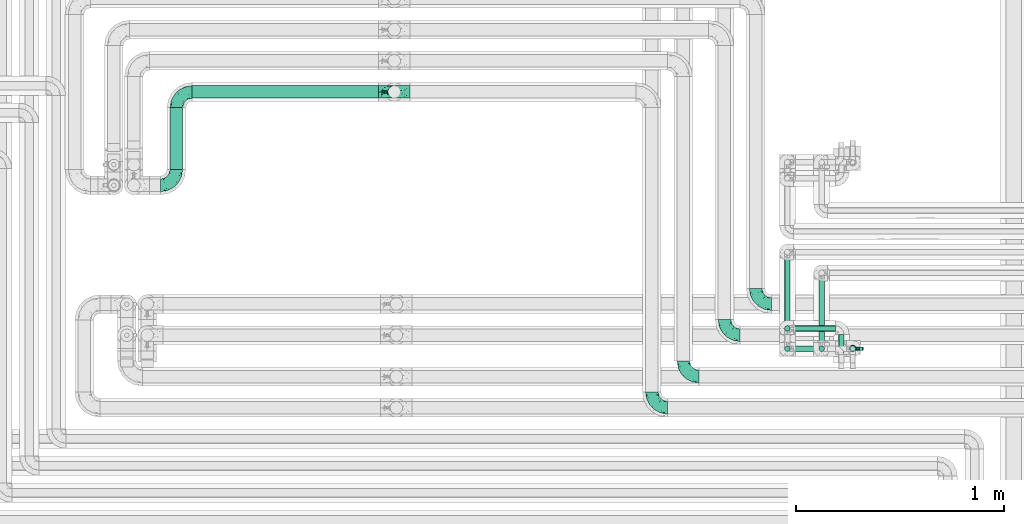
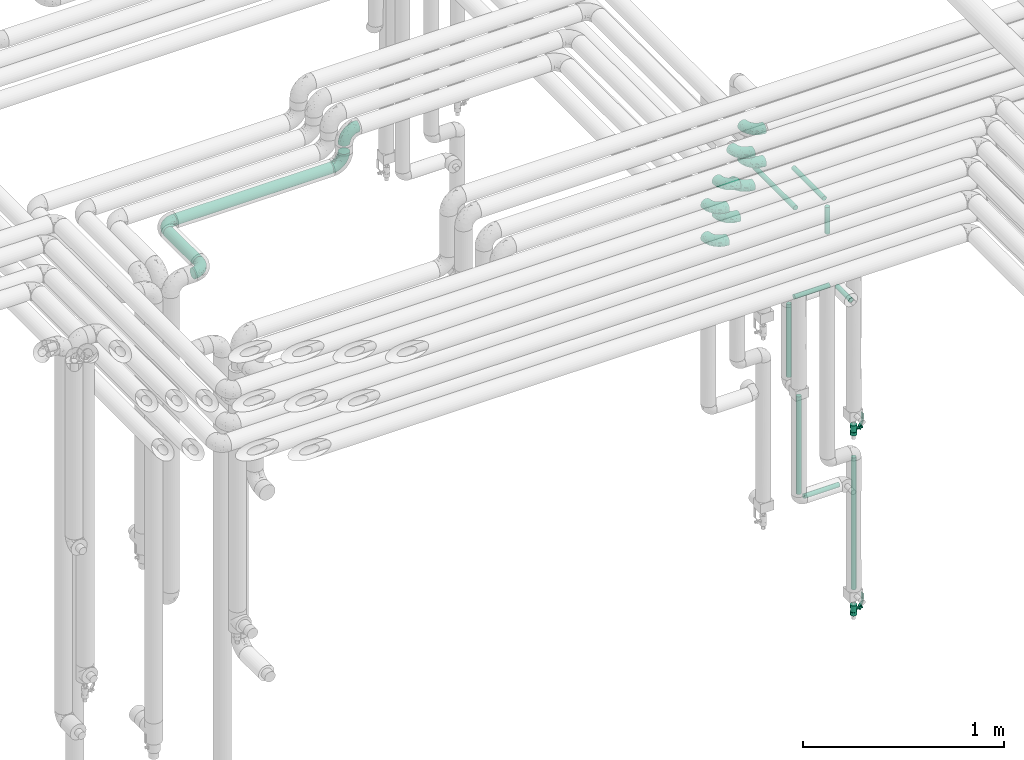
# One storey, part 635 of 827: 12 flow fittings, 11 flow segments, 2 flow controllers.
"""IFC2X3 building model written with IfcOpenShell, lengths in millimetres."""

from ifc_helpers import new_model, entity, si_unit, converted_unit, derived_unit, direction, frame, origin, origin_2d_with_axis, place, context, subcontext, project, spatial, polyline, circle, outline, extrude, faceted_brep, source, transform, mapped, material, material_list, type_object, type_shapes, element, save


model = new_model("IFC2X3")

# Units and contexts
model_context = context("Model", 3, precision=0.01, world=origin(), true_north=direction((6.12303176911189e-17, 1.0)))
body_context = subcontext(model_context, "Body", "Model", "MODEL_VIEW")
ifc_project = project(units=[si_unit("LENGTHUNIT", "METRE", prefix="MILLI"), si_unit("AREAUNIT", "SQUARE_METRE"), si_unit("VOLUMEUNIT", "CUBIC_METRE"), converted_unit("PLANEANGLEUNIT", "DEGREE", entity("IfcRatioMeasure", 0.0174532925199433), si_unit("PLANEANGLEUNIT", "RADIAN"), dimensions=[0, 0, 0, 0, 0, 0, 0]), si_unit("MASSUNIT", "GRAM", prefix="KILO"), derived_unit("MASSDENSITYUNIT", [(si_unit("MASSUNIT", "GRAM", prefix="KILO"), 1), (si_unit("LENGTHUNIT", "METRE"), -3)]), derived_unit("MOMENTOFINERTIAUNIT", [(si_unit("LENGTHUNIT", "METRE"), 4)]), si_unit("TIMEUNIT", "SECOND"), si_unit("FREQUENCYUNIT", "HERTZ"), si_unit("THERMODYNAMICTEMPERATUREUNIT", "DEGREE_CELSIUS"), derived_unit("THERMALTRANSMITTANCEUNIT", [(si_unit("MASSUNIT", "GRAM", prefix="KILO"), 1), (si_unit("THERMODYNAMICTEMPERATUREUNIT", "KELVIN"), -1), (si_unit("TIMEUNIT", "SECOND"), -3)]), derived_unit("VOLUMETRICFLOWRATEUNIT", [(si_unit("LENGTHUNIT", "METRE"), 3), (si_unit("TIMEUNIT", "SECOND"), -1)]), derived_unit("MASSFLOWRATEUNIT", [(si_unit("MASSUNIT", "GRAM", prefix="KILO"), 1), (si_unit("TIMEUNIT", "SECOND"), -1)]), derived_unit("ROTATIONALFREQUENCYUNIT", [(si_unit("TIMEUNIT", "SECOND"), -1)]), si_unit("ELECTRICCURRENTUNIT", "AMPERE"), si_unit("ELECTRICVOLTAGEUNIT", "VOLT"), si_unit("POWERUNIT", "WATT"), si_unit("FORCEUNIT", "NEWTON", prefix="KILO"), si_unit("ILLUMINANCEUNIT", "LUX"), si_unit("LUMINOUSFLUXUNIT", "LUMEN"), si_unit("LUMINOUSINTENSITYUNIT", "CANDELA"), derived_unit("USERDEFINED", [(si_unit("MASSUNIT", "GRAM", prefix="KILO"), -1), (si_unit("LENGTHUNIT", "METRE"), -2), (si_unit("TIMEUNIT", "SECOND"), 3), (si_unit("LUMINOUSFLUXUNIT", "LUMEN"), 1)]), derived_unit("LINEARVELOCITYUNIT", [(si_unit("LENGTHUNIT", "METRE"), 1), (si_unit("TIMEUNIT", "SECOND"), -1)]), si_unit("PRESSUREUNIT", "PASCAL"), derived_unit("USERDEFINED", [(si_unit("LENGTHUNIT", "METRE"), -2), (si_unit("MASSUNIT", "GRAM", prefix="KILO"), 1), (si_unit("TIMEUNIT", "SECOND"), -2)]), derived_unit("LINEARFORCEUNIT", [(si_unit("MASSUNIT", "GRAM", prefix="KILO"), 1), (si_unit("LENGTHUNIT", "METRE"), 1), (si_unit("TIMEUNIT", "SECOND"), -2), (si_unit("LENGTHUNIT", "METRE"), -1)]), derived_unit("PLANARFORCEUNIT", [(si_unit("MASSUNIT", "GRAM", prefix="KILO"), 1), (si_unit("LENGTHUNIT", "METRE"), 1), (si_unit("TIMEUNIT", "SECOND"), -2), (si_unit("LENGTHUNIT", "METRE"), -2)])], contexts=[model_context])

# Site, building, storey
site_placement = place(None, origin())
site = spatial("IfcSite", under=ifc_project, at=site_placement, CompositionType="ELEMENT")
building_placement = place(site_placement, origin())
building = spatial("IfcBuilding", under=site, at=building_placement, CompositionType="ELEMENT")
storey_placement = place(building_placement, frame((0.0, 0.0, 28200.0)))
storey = spatial("IfcBuildingStorey", under=building, at=storey_placement, Name="08", CompositionType="ELEMENT", Elevation=28200.0)

# Flow segments
pipe_segment_type = type_object("IfcPipeSegmentType", PredefinedType="NOTDEFINED")
flow_segment_1_placement = place(storey_placement, frame((31961.25, 16129.61, 2968.4)))
element("IfcFlowSegment", 1, at=flow_segment_1_placement, inside=storey, type_object=pipe_segment_type, context=body_context, shape_type="SweptSolid", body=[
    extrude(circle(Radius=30.0, at=origin_2d_with_axis()), frame((0.0, 31.6, 31.6), z_axis=(1.0, 0.0, 0.0), x_axis=(0.0, 1.0, 0.0)), (0.0, 0.0, 1.0), 897.780008999999),
])
flow_segment_2_placement = place(storey_placement, frame((31853.66, 15787.2, 2968.4)))
element("IfcFlowSegment", 2, at=flow_segment_2_placement, inside=storey, type_object=pipe_segment_type, context=body_context, shape_type="SweptSolid", body=[
    extrude(circle(Radius=30.0, at=origin_2d_with_axis()), frame((31.6, 0.0, 31.6), z_axis=(0.0, 1.0, 0.0), x_axis=(-1.0, 0.0, 0.0)), (0.0, 0.0, 1.0), 298.000000000006),
])
flow_segment_3_placement = place(storey_placement, frame((34812.85, 14909.92, 1089.1)))
element("IfcFlowSegment", 3, at=flow_segment_3_placement, inside=storey, type_object=pipe_segment_type, context=body_context, shape_type="SweptSolid", body=[
    extrude(circle(Radius=13.4, at=origin_2d_with_axis()), frame((15.0, 15.0, 0.0)), (0.0, 0.0, 1.0), 591.900000000008),
])
flow_segment_4_placement = place(storey_placement, frame((34856.95, 14909.92, 1045.0)))
element("IfcFlowSegment", 4, at=flow_segment_4_placement, inside=storey, type_object=pipe_segment_type, context=body_context, shape_type="SweptSolid", body=[
    extrude(circle(Radius=13.4, at=origin_2d_with_axis()), frame((0.0, 15.0, 15.0), z_axis=(1.0, 0.0, 0.0), x_axis=(0.0, -1.0, 0.0)), (0.0, 0.0, 1.0), 201.799999999997),
])
flow_segment_5_placement = place(storey_placement, frame((34856.95, 15006.91, 2195.0)))
element("IfcFlowSegment", 5, at=flow_segment_5_placement, inside=storey, type_object=pipe_segment_type, context=body_context, shape_type="SweptSolid", body=[
    extrude(circle(Radius=13.4, at=origin_2d_with_axis()), frame((0.0, 15.0, 15.0), z_axis=(1.0, 0.0, 0.0), x_axis=(0.0, 1.0, 0.0)), (0.0, 0.0, 1.0), 201.799999999997),
])
flow_segment_6_placement = place(storey_placement, frame((35072.85, 14854.91, 2195.0)))
element("IfcFlowSegment", 6, at=flow_segment_6_placement, inside=storey, type_object=pipe_segment_type, context=body_context, shape_type="SweptSolid", body=[
    extrude(circle(Radius=13.4, at=origin_2d_with_axis()), frame((15.0, 0.0, 15.0), z_axis=(0.0, 1.0, 0.0), x_axis=(1.0, 0.0, 0.0)), (0.0, 0.0, 1.0), 137.895089895177),
])
flow_segment_7_placement = place(storey_placement, frame((34812.85, 15006.91, 1739.1)))
element("IfcFlowSegment", 7, at=flow_segment_7_placement, inside=storey, type_object=pipe_segment_type, context=body_context, shape_type="SweptSolid", body=[
    extrude(circle(Radius=13.4, at=origin_2d_with_axis()), frame((15.0, 15.0, 0.0)), (0.0, 0.0, 1.0), 441.800000000021),
])
flow_segment_8_placement = place(storey_placement, frame((35127.89, 14909.92, 401.0)))
element("IfcFlowSegment", 8, at=flow_segment_8_placement, inside=storey, type_object=pipe_segment_type, context=body_context, shape_type="SweptSolid", body=[
    extrude(circle(Radius=13.4, at=origin_2d_with_axis()), frame((15.0, 15.0, 0.0)), (0.0, 0.0, 1.0), 799.899999999658),
])
flow_segment_9_placement = place(storey_placement, frame((34977.89, 14909.92, 2609.0)))
element("IfcFlowSegment", 9, at=flow_segment_9_placement, inside=storey, type_object=pipe_segment_type, context=body_context, shape_type="SweptSolid", body=[
    extrude(circle(Radius=13.4, at=origin_2d_with_axis()), frame((15.0, 15.0, 0.0), z_axis=(0.0, 0.0, 1.0), x_axis=(-1.0, 0.0, 0.0)), (0.0, 0.0, 1.0), 161.899999999968),
])
flow_segment_10_placement = place(storey_placement, frame((34977.89, 14954.01, 2785.0)))
element("IfcFlowSegment", 10, at=flow_segment_10_placement, inside=storey, type_object=pipe_segment_type, context=body_context, shape_type="SweptSolid", body=[
    extrude(circle(Radius=13.4, at=origin_2d_with_axis()), frame((15.0, 0.0, 15.0), z_axis=(0.0, 1.0, 0.0), x_axis=(-1.0, 0.0, 0.0)), (0.0, 0.0, 1.0), 306.888117846957),
])
flow_segment_11_placement = place(storey_placement, frame((34812.85, 14954.01, 2785.0)))
element("IfcFlowSegment", 11, at=flow_segment_11_placement, inside=storey, type_object=pipe_segment_type, context=body_context, shape_type="SweptSolid", body=[
    extrude(circle(Radius=13.4, at=origin_2d_with_axis()), frame((15.0, 0.0, 15.0), z_axis=(0.0, 1.0, 0.0), x_axis=(1.0, 0.0, 0.0)), (0.0, 0.0, 1.0), 406.488125846979),
])

# Flow controllers
ifc_material = material()
ifc_material_list = material_list([ifc_material, ifc_material, ifc_material, ifc_material, ifc_material])
valve_type = type_object("IfcValveType", PredefinedType="NOTDEFINED", material=ifc_material_list)
shared_shape_1 = source(origin(), body_context, "Body", "SweptSolid", [
    extrude(circle(Radius=17.5, at=origin_2d_with_axis()), frame((-30.5, 0.0, 0.0), z_axis=(1.0, 0.0, 0.0), x_axis=(0.0, 1.0, 0.0)), (0.0, 0.0, 1.0), 20.3333333333333),
    extrude(circle(Radius=16.0, at=origin_2d_with_axis()), frame((-10.17, 0.0, 0.0), z_axis=(1.0, 0.0, 0.0), x_axis=(0.0, 1.0, 0.0)), (0.0, 0.0, 1.0), 20.3333333333333),
    extrude(circle(Radius=17.5, at=origin_2d_with_axis()), frame((10.17, 0.0, 0.0), z_axis=(1.0, 0.0, 0.0), x_axis=(0.0, 1.0, 0.0)), (0.0, 0.0, 1.0), 20.3333333333333),
    extrude(outline(polyline([(-38.75, -5.0), (-38.75, -10.0), (-17.92, -10.0), (2.08, 5.0), (56.25, 5.0), (56.25, 10.0), (0.42, 10.0), (-19.58, -5.0), (-38.75, -5.0)])), frame((28.75, -8.75, 41.5), z_axis=(0.0, -1.0, 0.0), x_axis=(1.0, 0.0, 0.0)), (0.0, 0.0, -1.0), 17.5),
    extrude(circle(Radius=8.0, at=origin_2d_with_axis()), origin(), (0.0, 0.0, 1.0), 49.0),
])
type_shapes(valve_type, [shared_shape_1])
for number, where, z_axis, x_axis in (
    (12, (35142.88, 14924.91, 274.5), (1.0, 0.0, 0.0), (0.0, 0.0, 1.0)),
    (13, (35142.88, 14924.91, 1366.0), (1.0, 0.0, 0.0), (0.0, 0.0, 1.0)),
):
    element("IfcFlowController", number, at=place(storey_placement, frame(where, z_axis=z_axis, x_axis=x_axis)), inside=storey, type_object=valve_type, material=ifc_material, context=body_context, shape_type="MappedRepresentation", body=[
        mapped(shared_shape_1, transform((0.0, 0.0, 0.0), scale=1.0)),
    ])

# Flow fittings
pipe_fitting_type = type_object("IfcPipeFittingType", Name="ADSK_1", PredefinedType="NOTDEFINED", material=ifc_material)
shared_shape_2 = source(origin(), body_context, "Body", "Brep", [
    faceted_brep([(-76.0, 15.07, -26.11), (-76.0, 7.8, -29.12), (-76.0, 0.0, -30.15), (-76.0, -7.8, -29.12), (-76.0, -15.08, -26.11), (-76.0, -21.32, -21.32), (-76.0, -26.11, -15.08), (-76.0, -29.12, -7.8), (-76.0, -30.15, 0.0), (-76.0, -29.12, 7.8), (-76.0, -26.11, 15.07), (-76.0, -21.32, 21.32), (-76.0, -15.08, 26.11), (-76.0, -7.8, 29.12), (-76.0, 0.0, 30.15), (-76.0, 7.8, 29.12), (-76.0, 15.07, 26.11), (-76.0, 21.32, 21.32), (-76.0, 26.11, 15.07), (-76.0, 29.12, 7.8), (-76.0, 30.15, 0.0), (-76.0, 29.12, -7.8), (-76.0, 26.11, -15.08), (-76.0, 21.32, -21.32), (0.0, 76.0, -30.15), (-7.8, 76.0, -29.12), (-15.07, 76.0, -26.11), (-21.32, 76.0, -21.32), (-26.11, 76.0, -15.08), (-29.12, 76.0, -7.8), (-30.15, 76.0, 0.0), (-29.12, 76.0, 7.8), (-26.11, 76.0, 15.07), (-21.32, 76.0, 21.32), (-15.07, 76.0, 26.11), (-7.8, 76.0, 29.12), (0.0, 76.0, 30.15), (7.8, 76.0, 29.12), (15.08, 76.0, 26.11), (21.32, 76.0, 21.32), (26.11, 76.0, 15.07), (29.12, 76.0, 7.8), (30.15, 76.0, 0.0), (29.12, 76.0, -7.8), (26.11, 76.0, -15.08), (21.32, 76.0, -21.32), (15.08, 76.0, -26.11), (7.8, 76.0, -29.12), (10.79, 31.43, 21.07), (4.32, 31.7, 25.72), (1.65, 15.19, 19.92), (-61.17, -27.8, 0.0), (-51.1, -25.49, 9.84), (-56.14, -10.61, 27.27), (-31.7, -4.32, 25.72), (-39.75, 1.72, 29.41), (-43.2, -24.95, 0.0), (-1.86, 1.86, 0.0), (4.49, 7.65, 5.78), (-7.82, -4.61, 5.83), (-56.21, -22.79, 17.21), (-58.98, -3.38, 29.7), (-53.96, 5.6, 30.07), (-10.86, 10.86, 25.48), (-17.2, -2.6, 20.44), (-49.15, -16.01, 22.7), (-22.18, -14.24, 7.99), (-28.4, -17.42, 0.0), (-13.61, -9.88, 0.0), (-39.0, 23.48, 27.76), (-58.76, 12.54, 28.36), (-41.61, 15.41, 29.48), (16.01, 49.15, 22.7), (-58.55, 25.93, 19.53), (-51.53, 33.5, 13.51), (-64.92, 28.76, 12.4), (-7.48, 23.14, 28.25), (-1.72, 39.75, 29.41), (-12.04, 27.88, 29.88), (-63.91, 18.81, 24.52), (-11.63, 65.16, 28.18), (-4.97, 57.02, 30.05), (9.88, 13.61, 0.0), (-62.5, 31.74, 5.02), (-45.17, 30.98, 21.2), (-21.78, 9.76, 28.58), (10.61, 56.14, 27.27), (-32.09, 54.42, 13.26), (22.79, 56.21, 17.21), (15.38, 31.17, 15.63), (25.49, 51.1, 9.84), (21.84, 36.35, 5.92), (24.95, 43.2, 0.0), (3.38, 58.98, 29.7), (-31.17, -15.38, 15.63), (-39.39, 41.78, 15.45), (-34.56, 41.13, 20.79), (-39.81, -23.25, 5.49), (27.8, 61.17, 0.0), (-31.74, 62.5, 5.02), (-53.07, 36.29, 0.0), (-42.95, 42.95, 7.29), (-36.29, 53.07, 0.0), (-19.83, 58.51, 24.79), (-25.48, 60.2, 19.41), (-14.53, 50.96, 28.57), (-13.31, 37.09, 30.07), (-26.16, 40.06, 26.4), (-32.43, -10.35, 21.9), (17.42, 28.4, 0.0), (14.24, 22.18, 7.99), (-38.67, 9.72, 30.15), (-24.66, 17.36, 30.09), (-37.08, 31.49, 24.99), (-49.27, 22.83, 25.24), (-20.8, 38.81, 28.63), (-27.58, 27.58, 29.2), (-36.07, -20.23, 10.71), (-15.19, -6.16, 14.9), (6.6, 15.4, 14.49), (-2.51, 2.51, 11.35), (-65.16, 11.63, -28.18), (-49.15, -16.01, -22.7), (-57.02, 4.97, -30.05), (-25.93, 58.55, -19.53), (-33.5, 51.53, -13.51), (-28.76, 64.92, -12.4), (-60.2, 25.48, -19.41), (-58.51, 19.83, -24.79), (4.61, 7.82, -5.83), (-7.65, -4.49, -5.78), (-2.51, 2.51, -11.35), (-62.5, 31.74, -5.02), (-50.96, 14.53, -28.57), (-37.09, 13.31, -30.07), (-42.95, 42.95, -7.29), (25.49, 51.1, -9.84), (22.79, 56.21, -17.21), (-40.06, 26.16, -26.4), (3.38, 58.98, -29.7), (-5.6, 53.96, -30.07), (-27.88, 12.04, -29.88), (-9.76, 21.78, -28.58), (-23.14, 7.48, -28.25), (-51.1, -25.49, -9.84), (15.38, 31.17, -15.63), (16.01, 49.15, -22.7), (-23.48, 39.0, -27.76), (-12.54, 58.76, -28.36), (-15.41, 41.61, -29.48), (-56.21, -22.79, -17.21), (-9.72, 38.67, -30.15), (-17.36, 24.66, -30.09), (-22.18, -14.24, -7.99), (-41.13, 34.56, -20.79), (-31.74, 62.5, -5.02), (-58.98, -3.38, -29.7), (-31.17, -15.38, -15.63), (-56.14, -10.61, -27.27), (14.24, 22.18, -7.99), (23.25, 39.81, -5.49), (-31.49, 37.08, -24.99), (-15.19, -6.16, -14.9), (1.65, 15.19, -19.92), (-18.81, 63.91, -24.52), (-32.59, -11.62, -20.84), (-31.7, -4.32, -25.72), (-17.2, -2.6, -20.44), (-39.75, 1.72, -29.41), (-54.42, 32.09, -13.26), (-30.98, 45.17, -21.2), (10.61, 56.14, -27.27), (10.23, 31.31, -21.52), (4.32, 31.7, -25.72), (-41.78, 39.39, -15.45), (-1.72, 39.75, -29.41), (-36.35, -21.84, -5.92), (-22.83, 49.27, -25.24), (-38.81, 20.8, -28.63), (-27.58, 27.58, -29.2), (-10.86, 10.86, -25.48), (20.23, 36.07, -10.71), (6.6, 15.4, -14.49)], [[[0, 1, 2, 3, 4, 5, 6, 7, 8, 9, 10, 11, 12, 13, 14, 15, 16, 17, 18, 19, 20, 21, 22, 23]], [[24, 25, 26, 27, 28, 29, 30, 31, 32, 33, 34, 35, 36, 37, 38, 39, 40, 41, 42, 43, 44, 45, 46, 47]], [[48, 49, 50]], [[51, 52, 9]], [[53, 54, 55]], [[9, 52, 10]], [[56, 52, 51]], [[57, 58, 59]], [[11, 10, 60]], [[14, 61, 62]], [[63, 54, 64]], [[65, 12, 11]], [[65, 53, 12]], [[66, 67, 68]], [[69, 70, 71]], [[72, 39, 38]], [[73, 74, 75]], [[15, 70, 16]], [[76, 77, 78]], [[16, 79, 17]], [[13, 61, 14]], [[35, 80, 81]], [[14, 62, 15]], [[17, 73, 18]], [[57, 82, 58]], [[20, 19, 83]], [[75, 19, 18]], [[70, 15, 62]], [[73, 84, 74]], [[78, 85, 76]], [[38, 86, 72]], [[32, 31, 87]], [[88, 89, 90]], [[91, 92, 90]], [[72, 86, 49]], [[36, 93, 37]], [[75, 83, 19]], [[36, 35, 81]], [[60, 94, 65]], [[40, 90, 41]], [[95, 96, 87]], [[88, 90, 40]], [[66, 97, 67]], [[90, 98, 41]], [[40, 39, 88]], [[99, 31, 30]], [[20, 83, 100]], [[101, 102, 100]], [[52, 60, 10]], [[102, 99, 30]], [[96, 103, 104]], [[83, 101, 100]], [[12, 53, 13]], [[104, 103, 33]], [[105, 106, 81]], [[107, 105, 103]], [[64, 54, 108]], [[80, 103, 105]], [[80, 35, 34]], [[34, 33, 103]], [[86, 38, 37]], [[109, 110, 82]], [[71, 111, 112]], [[69, 107, 113]], [[79, 73, 17]], [[114, 113, 84]], [[33, 32, 104]], [[115, 107, 116]], [[105, 115, 106]], [[93, 81, 77]], [[54, 53, 65]], [[61, 53, 55]], [[108, 94, 64]], [[54, 63, 85]], [[93, 86, 37]], [[77, 76, 49]], [[77, 49, 86]], [[49, 63, 50]], [[60, 52, 117]], [[65, 11, 60]], [[39, 72, 88]], [[89, 88, 72]], [[71, 70, 62]], [[79, 70, 114]], [[103, 96, 107]], [[69, 113, 114]], [[112, 106, 116]], [[77, 81, 106]], [[112, 116, 71]], [[112, 55, 85]], [[64, 50, 63]], [[57, 59, 68]], [[32, 87, 104]], [[96, 104, 87]], [[94, 118, 64]], [[50, 119, 89]], [[50, 64, 118]], [[50, 89, 48]], [[81, 93, 36]], [[86, 93, 77]], [[53, 61, 13]], [[62, 61, 55]], [[71, 62, 111]], [[69, 71, 116]], [[95, 101, 74]], [[99, 101, 87]], [[118, 66, 59]], [[117, 97, 66]], [[117, 66, 94]], [[91, 89, 110]], [[91, 110, 109]], [[110, 89, 119]], [[9, 8, 51]], [[98, 90, 92]], [[98, 42, 41]], [[101, 83, 74]], [[101, 99, 102]], [[87, 31, 99]], [[62, 55, 111]], [[55, 112, 111]], [[107, 69, 116]], [[70, 69, 114]], [[107, 96, 113]], [[84, 113, 96]], [[84, 96, 95]], [[114, 84, 73]], [[70, 79, 16]], [[73, 79, 114]], [[54, 85, 55]], [[76, 85, 63]], [[49, 76, 63]], [[77, 106, 78]], [[106, 112, 78]], [[85, 78, 112]], [[73, 75, 18]], [[83, 75, 74]], [[103, 80, 34]], [[81, 80, 105]], [[101, 95, 87]], [[84, 95, 74]], [[106, 115, 116]], [[105, 107, 115]], [[120, 59, 58]], [[82, 110, 58]], [[119, 58, 110]], [[118, 59, 120]], [[66, 68, 59]], [[54, 65, 108]], [[94, 108, 65]], [[66, 118, 94]], [[50, 118, 120]], [[50, 120, 119]], [[119, 120, 58]], [[89, 72, 48]], [[49, 48, 72]], [[60, 117, 94]], [[117, 52, 97]], [[52, 56, 97]], [[67, 97, 56]], [[92, 91, 109]], [[89, 91, 90]], [[121, 1, 0]], [[122, 5, 4]], [[2, 1, 123]], [[124, 125, 126]], [[127, 128, 23]], [[129, 130, 131]], [[100, 132, 20]], [[133, 134, 123]], [[135, 100, 102]], [[136, 137, 44]], [[133, 128, 138]], [[24, 139, 140]], [[141, 142, 143]], [[121, 128, 133]], [[6, 144, 7]], [[137, 145, 146]], [[144, 51, 7]], [[147, 148, 149]], [[144, 6, 150]], [[149, 151, 152]], [[153, 68, 67]], [[154, 128, 127]], [[30, 155, 102]], [[43, 42, 98]], [[156, 3, 2]], [[157, 144, 150]], [[158, 4, 3]], [[24, 140, 25]], [[155, 135, 102]], [[159, 160, 109]], [[30, 29, 155]], [[147, 138, 161]], [[27, 124, 28]], [[57, 129, 82]], [[162, 163, 131]], [[27, 26, 164]], [[148, 26, 25]], [[165, 166, 167]], [[24, 47, 139]], [[143, 168, 141]], [[22, 21, 169]], [[125, 124, 170]], [[148, 25, 140]], [[46, 146, 171]], [[158, 122, 4]], [[0, 23, 128]], [[1, 121, 123]], [[109, 82, 159]], [[45, 44, 137]], [[146, 46, 45]], [[136, 43, 98]], [[132, 21, 20]], [[136, 98, 92]], [[172, 173, 146]], [[46, 171, 47]], [[43, 136, 44]], [[174, 154, 169]], [[171, 173, 175]], [[6, 5, 150]], [[126, 29, 28]], [[176, 56, 144]], [[122, 158, 166]], [[164, 124, 27]], [[177, 161, 170]], [[23, 22, 127]], [[178, 138, 179]], [[133, 178, 134]], [[156, 123, 168]], [[156, 158, 3]], [[168, 143, 166]], [[168, 166, 158]], [[166, 180, 167]], [[173, 171, 146]], [[139, 171, 175]], [[172, 145, 163]], [[173, 180, 142]], [[5, 122, 150]], [[157, 150, 122]], [[137, 136, 181]], [[146, 45, 137]], [[149, 148, 140]], [[164, 148, 177]], [[128, 154, 138]], [[147, 161, 177]], [[152, 134, 179]], [[168, 123, 134]], [[152, 179, 149]], [[152, 175, 142]], [[57, 130, 129]], [[157, 165, 167]], [[22, 169, 127]], [[154, 127, 169]], [[163, 167, 180]], [[162, 157, 167]], [[173, 163, 180]], [[182, 163, 145]], [[123, 156, 2]], [[158, 156, 168]], [[171, 139, 47]], [[140, 139, 175]], [[149, 140, 151]], [[147, 149, 179]], [[174, 135, 125]], [[132, 135, 169]], [[176, 157, 153]], [[176, 153, 67]], [[153, 157, 162]], [[182, 159, 129]], [[181, 160, 159]], [[181, 159, 145]], [[51, 144, 56]], [[51, 8, 7]], [[135, 132, 100]], [[169, 21, 132]], [[126, 155, 29]], [[135, 155, 125]], [[140, 175, 151]], [[175, 152, 151]], [[138, 147, 179]], [[148, 147, 177]], [[138, 154, 161]], [[170, 161, 154]], [[170, 154, 174]], [[177, 170, 124]], [[148, 164, 26]], [[124, 164, 177]], [[173, 142, 175]], [[143, 142, 180]], [[166, 143, 180]], [[168, 134, 141]], [[134, 152, 141]], [[142, 141, 152]], [[124, 126, 28]], [[155, 126, 125]], [[128, 121, 0]], [[123, 121, 133]], [[135, 174, 169]], [[170, 174, 125]], [[134, 178, 179]], [[133, 138, 178]], [[130, 153, 162]], [[68, 153, 130]], [[57, 68, 130]], [[182, 129, 131]], [[159, 82, 129]], [[157, 122, 165]], [[166, 165, 122]], [[163, 162, 167]], [[162, 131, 130]], [[145, 172, 146]], [[163, 173, 172]], [[159, 182, 145]], [[131, 163, 182]], [[56, 176, 67]], [[157, 176, 144]], [[137, 181, 145]], [[181, 136, 160]], [[136, 92, 160]], [[109, 160, 92]]]),
])
type_shapes(pipe_fitting_type, [shared_shape_2])
for number, where, z_axis, x_axis, name in (
    (14, (34675.03, 15139.0, 3000.0), (0.0, 0.0, 1.0), (0.0, -1.0, 0.0), "ADSK_1"),
    (15, (34525.03, 14989.0, 3000.0), (0.0, 0.0, 1.0), (0.0, -1.0, 0.0), "ADSK_1"),
    (16, (34326.66, 14790.0, 3000.0), (0.0, 0.0, 1.0), (0.0, -1.0, 0.0), "ADSK_1"),
    (17, (34675.03, 15139.0, 3200.0), (0.0, 0.0, 1.0), (0.0, -1.0, 0.0), "ADSK_1"),
    (18, (34326.66, 14790.0, 3200.0), (0.0, 0.0, 1.0), (0.0, -1.0, 0.0), "ADSK_1"),
    (19, (32935.03, 16161.2, 3200.0), (0.0, -1.0, 0.0), (-1.0, 0.0, 0.0), "ADSK_1"),
    (20, (32935.03, 16161.2, 3000.0), (0.0, 1.0, 0.0), (0.0, 0.0, -1.0), "ADSK_1"),
    (21, (31885.25, 16161.2, 3000.0), (0.0, 0.0, 1.0), (-1.0, 0.0, 0.0), "ADSK_1"),
):
    element("IfcFlowFitting", number, at=place(storey_placement, frame(where, z_axis=z_axis, x_axis=x_axis)), inside=storey, type_object=pipe_fitting_type, material=ifc_material, Name=name, ObjectType="ADSK_1", context=body_context, shape_type="MappedRepresentation", body=[
        mapped(shared_shape_2, transform((0.0, 0.0, 0.0), scale=1.0)),
    ])
flow_fitting_placement = place(storey_placement, frame((31885.25, 15711.2, 3000.0)))
element("IfcFlowFitting", 22, at=flow_fitting_placement, inside=storey, type_object=pipe_fitting_type, material=ifc_material, Name="ADSK_1", ObjectType="ADSK_1", context=body_context, shape_type="MappedRepresentation", body=[
    mapped(shared_shape_2, transform((0.0, 0.0, 0.0), scale=1.0)),
])
for number, where, z_axis, x_axis, name in (
    (23, (34175.03, 14640.0, 3000.0), (0.0, 0.0, 1.0), (0.0, -1.0, 0.0), "ADSK_1"),
    (24, (34525.03, 14989.0, 3200.0), (0.0, 0.0, 1.0), (0.0, -1.0, 0.0), "ADSK_1"),
    (25, (34175.03, 14640.0, 3200.0), (0.0, 0.0, 1.0), (0.0, -1.0, 0.0), "ADSK_1"),
):
    element("IfcFlowFitting", number, at=place(storey_placement, frame(where, z_axis=z_axis, x_axis=x_axis)), inside=storey, type_object=pipe_fitting_type, material=ifc_material, Name=name, ObjectType="ADSK_1", context=body_context, shape_type="MappedRepresentation", body=[
        mapped(shared_shape_2, transform((0.0, 0.0, 0.0), scale=1.0)),
    ])

save(model, "model.ifc")
